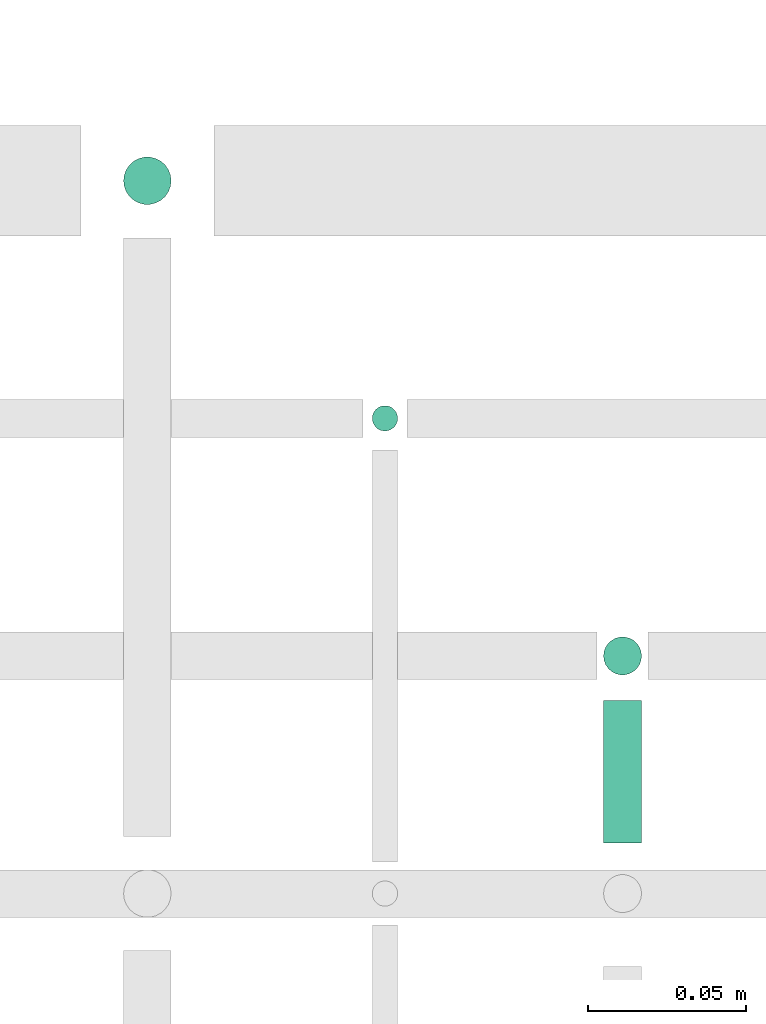
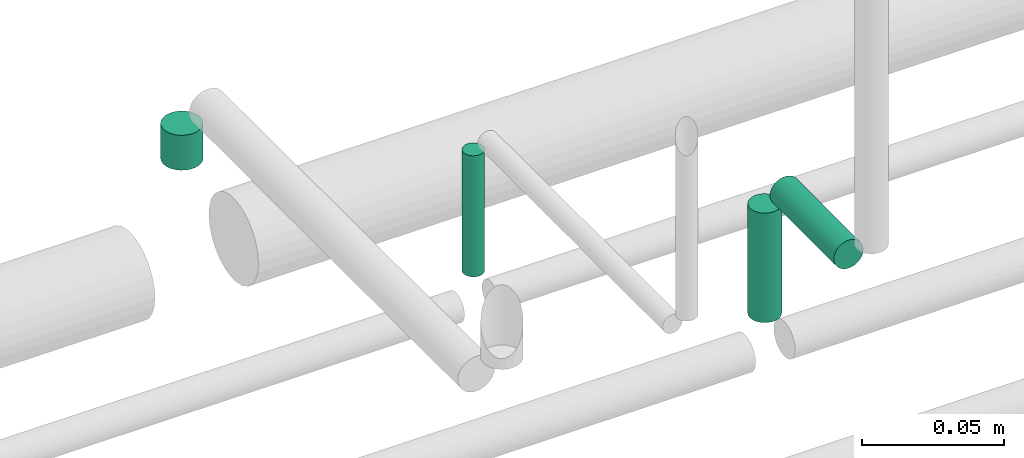
# One storey, part 56 of 65: 4 flow segments.
"""IFC2X3 building model written with IfcOpenShell, lengths in millimetres."""

from ifc_helpers import new_model, entity, si_unit, converted_unit, derived_unit, direction, frame, frame_2d, origin, origin_2d_with_axis, place, context, subcontext, project, spatial, circle, extrude, type_object, element, save


model = new_model("IFC2X3")

# Units and contexts
model_context = context("Model", 3, precision=0.01, world=origin(), true_north=direction((6.12303176911189e-17, 1.0)))
body_context = subcontext(model_context, "Body", "Model", "MODEL_VIEW")
ifc_project = project(units=[si_unit("LENGTHUNIT", "METRE", prefix="MILLI"), si_unit("AREAUNIT", "SQUARE_METRE"), si_unit("VOLUMEUNIT", "CUBIC_METRE"), converted_unit("PLANEANGLEUNIT", "DEGREE", entity("IfcRatioMeasure", 0.0174532925199433), si_unit("PLANEANGLEUNIT", "RADIAN"), dimensions=[0, 0, 0, 0, 0, 0, 0]), si_unit("MASSUNIT", "GRAM", prefix="KILO"), derived_unit("MASSDENSITYUNIT", [(si_unit("MASSUNIT", "GRAM", prefix="KILO"), 1), (si_unit("LENGTHUNIT", "METRE"), -3)]), derived_unit("MOMENTOFINERTIAUNIT", [(si_unit("LENGTHUNIT", "METRE"), 4)]), si_unit("TIMEUNIT", "SECOND"), si_unit("FREQUENCYUNIT", "HERTZ"), si_unit("THERMODYNAMICTEMPERATUREUNIT", "DEGREE_CELSIUS"), derived_unit("THERMALTRANSMITTANCEUNIT", [(si_unit("MASSUNIT", "GRAM", prefix="KILO"), 1), (si_unit("THERMODYNAMICTEMPERATUREUNIT", "KELVIN"), -1), (si_unit("TIMEUNIT", "SECOND"), -3)]), derived_unit("VOLUMETRICFLOWRATEUNIT", [(si_unit("LENGTHUNIT", "METRE"), 3), (si_unit("TIMEUNIT", "SECOND"), -1)]), derived_unit("MASSFLOWRATEUNIT", [(si_unit("MASSUNIT", "GRAM", prefix="KILO"), 1), (si_unit("TIMEUNIT", "SECOND"), -1)]), derived_unit("ROTATIONALFREQUENCYUNIT", [(si_unit("TIMEUNIT", "SECOND"), -1)]), si_unit("ELECTRICCURRENTUNIT", "AMPERE"), si_unit("ELECTRICVOLTAGEUNIT", "VOLT"), si_unit("POWERUNIT", "WATT"), si_unit("FORCEUNIT", "NEWTON", prefix="KILO"), si_unit("ILLUMINANCEUNIT", "LUX"), si_unit("LUMINOUSFLUXUNIT", "LUMEN"), si_unit("LUMINOUSINTENSITYUNIT", "CANDELA"), derived_unit("USERDEFINED", [(si_unit("MASSUNIT", "GRAM", prefix="KILO"), -1), (si_unit("LENGTHUNIT", "METRE"), -2), (si_unit("TIMEUNIT", "SECOND"), 3), (si_unit("LUMINOUSFLUXUNIT", "LUMEN"), 1)]), derived_unit("LINEARVELOCITYUNIT", [(si_unit("LENGTHUNIT", "METRE"), 1), (si_unit("TIMEUNIT", "SECOND"), -1)]), si_unit("PRESSUREUNIT", "PASCAL"), derived_unit("USERDEFINED", [(si_unit("LENGTHUNIT", "METRE"), -2), (si_unit("MASSUNIT", "GRAM", prefix="KILO"), 1), (si_unit("TIMEUNIT", "SECOND"), -2)]), derived_unit("LINEARFORCEUNIT", [(si_unit("MASSUNIT", "GRAM", prefix="KILO"), 1), (si_unit("LENGTHUNIT", "METRE"), 1), (si_unit("TIMEUNIT", "SECOND"), -2), (si_unit("LENGTHUNIT", "METRE"), -1)]), derived_unit("PLANARFORCEUNIT", [(si_unit("MASSUNIT", "GRAM", prefix="KILO"), 1), (si_unit("LENGTHUNIT", "METRE"), 1), (si_unit("TIMEUNIT", "SECOND"), -2), (si_unit("LENGTHUNIT", "METRE"), -2)])], contexts=[model_context])

# Site, building, storey
site_placement = place(None, frame((0.0, -0.00077364408347762, 0.0)))
site = spatial("IfcSite", under=ifc_project, at=site_placement, CompositionType="ELEMENT")
building_placement = place(site_placement, origin())
building = spatial("IfcBuilding", under=site, at=building_placement, CompositionType="ELEMENT")
storey_placement = place(building_placement, frame((0.0, 0.0, 19800.0)))
storey = spatial("IfcBuildingStorey", under=building, at=storey_placement, CompositionType="ELEMENT", Elevation=19800.0)

# Flow segments
pipe_segment_type = type_object("IfcPipeSegmentType", PredefinedType="NOTDEFINED")
flow_segment_1_placement = place(storey_placement, frame((56477.0132626869, 7880.90472776409, 2592.0)))
element("IfcFlowSegment", 1, at=flow_segment_1_placement, inside=storey, type_object=pipe_segment_type, context=body_context, shape_type="SweptSolid", body=[
    extrude(circle(Radius=7.5, at=frame_2d((-8.66293703438714e-12, 0.0), x_axis=(1.0, 0.0))), frame((9.09527223590553, 9.09527223591636, 0.0), z_axis=(0.0, 0.0, 1.0), x_axis=(-1.0, 0.0, 0.0)), (0.0, 0.0, 1.0), 15.0000000000009),
])
flow_segment_2_placement = place(storey_placement, frame((56555.5132626869, 7809.40472776405, 2563.0)))
element("IfcFlowSegment", 2, at=flow_segment_2_placement, inside=storey, type_object=pipe_segment_type, context=body_context, shape_type="SweptSolid", body=[
    extrude(circle(Radius=4.0, at=frame_2d((0.0, -1.08286712929839e-12), x_axis=(1.0, 0.0))), frame((5.59527223591499, 5.59527223591499, 0.0), z_axis=(0.0, 0.0, 1.0), x_axis=(-1.0, 0.0, 0.0)), (0.0, 0.0, 1.0), 51.9999999998539),
])
flow_segment_3_placement = place(storey_placement, frame((56628.5132626869, 7681.0, 2617.40472776395)))
element("IfcFlowSegment", 3, at=flow_segment_3_placement, inside=storey, type_object=pipe_segment_type, context=body_context, shape_type="SweptSolid", body=[
    extrude(circle(Radius=6.0, at=origin_2d_with_axis()), frame((7.59527223591454, 0.0, 7.59527223591454), z_axis=(0.0, 1.0, 0.0), x_axis=(-1.0, 0.0, 0.0)), (0.0, 0.0, 1.0), 45.0000000000266),
])
flow_segment_4_placement = place(storey_placement, frame((56628.5132626869, 7732.40472776407, 2564.0)))
element("IfcFlowSegment", 4, at=flow_segment_4_placement, inside=storey, type_object=pipe_segment_type, context=body_context, shape_type="SweptSolid", body=[
    extrude(circle(Radius=6.0, at=frame_2d((0.0, -1.08286712929839e-12), x_axis=(1.0, 0.0))), frame((7.59527223591454, 7.59527223591454, 0.0), z_axis=(0.0, 0.0, 1.0), x_axis=(-1.0, 0.0, 0.0)), (0.0, 0.0, 1.0), 46.999999999868),
])

save(model, "model.ifc")
